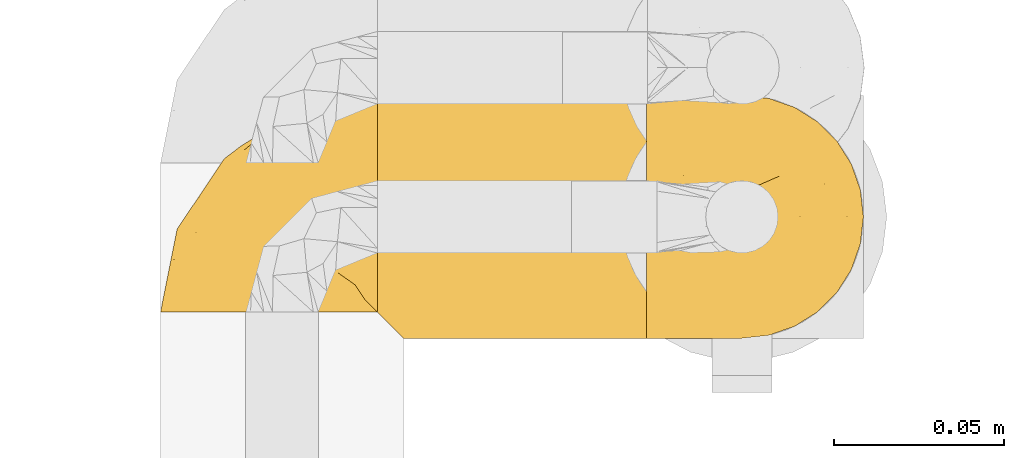
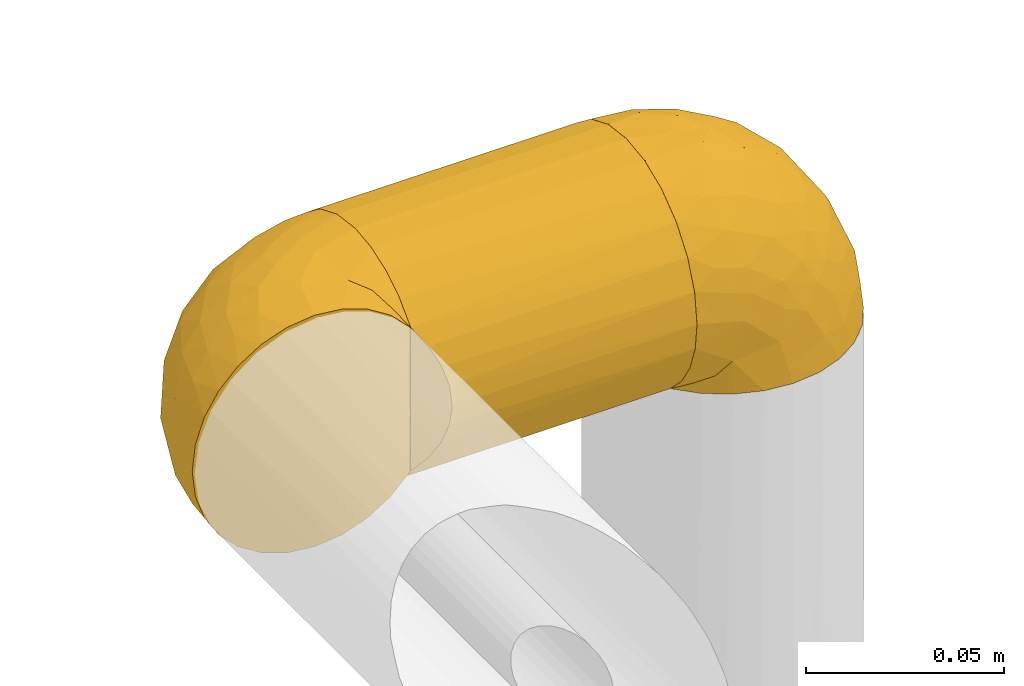
# One storey, part 69 of 827: 3 coverings.
"""IFC2X3 building model written with IfcOpenShell, lengths in millimetres."""

from ifc_helpers import new_model, entity, si_unit, converted_unit, derived_unit, direction, frame, origin, place, context, subcontext, project, spatial, faceted_brep, element, save


model = new_model("IFC2X3")

# Units and contexts
model_context = context("Model", 3, precision=0.01, world=origin(), true_north=direction((6.12303176911189e-17, 1.0)))
body_context = subcontext(model_context, "Body", "Model", "MODEL_VIEW")
ifc_project = project(units=[si_unit("LENGTHUNIT", "METRE", prefix="MILLI"), si_unit("AREAUNIT", "SQUARE_METRE"), si_unit("VOLUMEUNIT", "CUBIC_METRE"), converted_unit("PLANEANGLEUNIT", "DEGREE", entity("IfcRatioMeasure", 0.0174532925199433), si_unit("PLANEANGLEUNIT", "RADIAN"), dimensions=[0, 0, 0, 0, 0, 0, 0]), si_unit("MASSUNIT", "GRAM", prefix="KILO"), derived_unit("MASSDENSITYUNIT", [(si_unit("MASSUNIT", "GRAM", prefix="KILO"), 1), (si_unit("LENGTHUNIT", "METRE"), -3)]), derived_unit("MOMENTOFINERTIAUNIT", [(si_unit("LENGTHUNIT", "METRE"), 4)]), si_unit("TIMEUNIT", "SECOND"), si_unit("FREQUENCYUNIT", "HERTZ"), si_unit("THERMODYNAMICTEMPERATUREUNIT", "DEGREE_CELSIUS"), derived_unit("THERMALTRANSMITTANCEUNIT", [(si_unit("MASSUNIT", "GRAM", prefix="KILO"), 1), (si_unit("THERMODYNAMICTEMPERATUREUNIT", "KELVIN"), -1), (si_unit("TIMEUNIT", "SECOND"), -3)]), derived_unit("VOLUMETRICFLOWRATEUNIT", [(si_unit("LENGTHUNIT", "METRE"), 3), (si_unit("TIMEUNIT", "SECOND"), -1)]), derived_unit("MASSFLOWRATEUNIT", [(si_unit("MASSUNIT", "GRAM", prefix="KILO"), 1), (si_unit("TIMEUNIT", "SECOND"), -1)]), derived_unit("ROTATIONALFREQUENCYUNIT", [(si_unit("TIMEUNIT", "SECOND"), -1)]), si_unit("ELECTRICCURRENTUNIT", "AMPERE"), si_unit("ELECTRICVOLTAGEUNIT", "VOLT"), si_unit("POWERUNIT", "WATT"), si_unit("FORCEUNIT", "NEWTON", prefix="KILO"), si_unit("ILLUMINANCEUNIT", "LUX"), si_unit("LUMINOUSFLUXUNIT", "LUMEN"), si_unit("LUMINOUSINTENSITYUNIT", "CANDELA"), derived_unit("USERDEFINED", [(si_unit("MASSUNIT", "GRAM", prefix="KILO"), -1), (si_unit("LENGTHUNIT", "METRE"), -2), (si_unit("TIMEUNIT", "SECOND"), 3), (si_unit("LUMINOUSFLUXUNIT", "LUMEN"), 1)]), derived_unit("LINEARVELOCITYUNIT", [(si_unit("LENGTHUNIT", "METRE"), 1), (si_unit("TIMEUNIT", "SECOND"), -1)]), si_unit("PRESSUREUNIT", "PASCAL"), derived_unit("USERDEFINED", [(si_unit("LENGTHUNIT", "METRE"), -2), (si_unit("MASSUNIT", "GRAM", prefix="KILO"), 1), (si_unit("TIMEUNIT", "SECOND"), -2)]), derived_unit("LINEARFORCEUNIT", [(si_unit("MASSUNIT", "GRAM", prefix="KILO"), 1), (si_unit("LENGTHUNIT", "METRE"), 1), (si_unit("TIMEUNIT", "SECOND"), -2), (si_unit("LENGTHUNIT", "METRE"), -1)]), derived_unit("PLANARFORCEUNIT", [(si_unit("MASSUNIT", "GRAM", prefix="KILO"), 1), (si_unit("LENGTHUNIT", "METRE"), 1), (si_unit("TIMEUNIT", "SECOND"), -2), (si_unit("LENGTHUNIT", "METRE"), -2)])], contexts=[model_context])

# Site, building, storey
site_placement = place(None, origin())
site = spatial("IfcSite", under=ifc_project, at=site_placement, CompositionType="ELEMENT")
building_placement = place(site_placement, origin())
building = spatial("IfcBuilding", under=site, at=building_placement, CompositionType="ELEMENT")
storey_placement = place(building_placement, frame((0.0, 0.0, 28200.0)))
storey = spatial("IfcBuildingStorey", under=building, at=storey_placement, Name="08", CompositionType="ELEMENT", Elevation=28200.0)

# Coverings
covering_1_placement = place(storey_placement, frame((13301.52, 12341.57, 1262.75)))
element("IfcCovering", 1, at=covering_1_placement, inside=storey, Name=":ADSK_", ObjectType=":ADSK_", PredefinedType="INSULATION", context=body_context, shape_type="Brep", body=[
    faceted_brep([(80.6, 71.99, 29.25), (80.6, 72.9, 37.25), (80.6, 71.68, 46.47), (80.6, 68.12, 55.07), (80.6, 62.45, 62.45), (80.6, 55.07, 68.12), (80.6, 46.47, 71.68), (80.6, 37.25, 72.9), (80.6, 28.02, 71.68), (80.6, 19.42, 68.12), (80.6, 12.04, 62.45), (80.6, 6.37, 55.07), (80.6, 2.81, 46.47), (80.6, 1.6, 37.25), (80.6, 2.5, 29.26), (80.6, 5.17, 21.68), (80.6, 9.47, 14.9), (80.6, 15.18, 9.25), (80.6, 59.31, 9.25), (80.6, 65.02, 14.89), (80.6, 69.32, 21.68), (1.6, 71.68, 28.02), (1.6, 68.12, 19.42), (1.6, 62.45, 12.04), (1.6, 55.07, 6.37), (1.6, 46.47, 2.81), (1.6, 37.25, 1.6), (1.6, 29.26, 2.5), (1.6, 21.68, 5.17), (1.6, 14.89, 9.47), (1.6, 9.25, 15.18), (1.6, 9.25, 59.31), (1.6, 14.89, 65.02), (1.6, 21.68, 69.32), (1.6, 29.26, 71.99), (1.6, 37.25, 72.9), (1.6, 46.47, 71.68), (1.6, 55.07, 68.12), (1.6, 62.45, 62.45), (1.6, 68.12, 55.07), (1.6, 71.68, 46.47), (1.6, 72.9, 37.25), (8.75, 2.09, 31.32), (7.28, 3.56, 25.57), (4.87, 5.97, 20.14), (9.25, 1.6, 37.25), (77.32, 20.14, 5.97), (74.91, 25.57, 3.56), (73.44, 31.32, 2.09), (72.95, 37.25, 1.6), (73.44, 43.17, 2.09), (74.91, 48.92, 3.56), (77.32, 54.35, 5.97), (4.87, 5.97, 54.35), (7.28, 3.56, 48.92), (8.75, 2.09, 43.17)], [[[0, 1, 2, 3, 4, 5, 6, 7, 8, 9, 10, 11, 12, 13, 14, 15, 16, 17, 18, 19, 20]], [[21, 22, 23, 24, 25, 26, 27, 28, 29, 30, 31, 32, 33, 34, 35, 36, 37, 38, 39, 40, 41]], [[42, 43, 14]], [[44, 30, 16]], [[43, 44, 15]], [[45, 42, 13]], [[13, 42, 14]], [[14, 43, 15]], [[44, 16, 15]], [[30, 29, 16]], [[46, 29, 28]], [[47, 28, 27]], [[48, 27, 26]], [[46, 17, 29]], [[48, 47, 27]], [[49, 48, 26]], [[46, 28, 47]], [[29, 17, 16]], [[50, 49, 26]], [[50, 26, 25]], [[51, 25, 24]], [[51, 50, 25]], [[18, 52, 24]], [[51, 24, 52]], [[24, 23, 18]], [[19, 23, 22]], [[20, 22, 21]], [[0, 21, 41]], [[19, 22, 20]], [[20, 21, 0]], [[41, 1, 0]], [[23, 19, 18]], [[2, 1, 41, 40]], [[3, 2, 40, 39]], [[39, 38, 4, 3]], [[6, 5, 37, 36]], [[7, 6, 36, 35]], [[38, 37, 5, 4]], [[7, 35, 34]], [[8, 34, 33]], [[9, 33, 32]], [[7, 34, 8]], [[8, 33, 9]], [[32, 10, 9]], [[32, 31, 10]], [[31, 53, 11]], [[54, 55, 12]], [[53, 54, 11]], [[11, 54, 12]], [[13, 12, 55]], [[45, 13, 55]], [[31, 11, 10]], [[49, 50, 51, 52, 18, 17, 46, 47, 48]], [[30, 44, 43, 42, 45, 55, 54, 53, 31]]]),
])
covering_2_placement = place(storey_placement, frame((13237.87, 12349.22, 1262.75)))
element("IfcCovering", 2, at=covering_2_placement, inside=storey, Name=":ADSK_", ObjectType=":ADSK_", PredefinedType="INSULATION", context=body_context, shape_type="Brep", body=[
    faceted_brep([(21.77, 1.6, 69.36), (15.01, 1.6, 65.11), (9.37, 1.6, 59.47), (5.12, 1.6, 52.71), (2.49, 1.6, 45.17), (1.6, 1.6, 37.25), (2.49, 1.6, 29.31), (5.13, 1.6, 21.77), (9.38, 1.6, 15.01), (15.02, 1.6, 9.37), (21.78, 1.6, 5.12), (29.32, 1.6, 2.49), (37.25, 1.6, 1.6), (45.15, 1.6, 2.48), (52.65, 1.6, 5.1), (59.39, 1.6, 9.31), (65.02, 1.6, 14.9), (65.02, 1.6, 16.96), (65.02, 1.6, 18.43), (65.02, 1.6, 20.19), (65.02, 1.6, 21.96), (65.02, 1.6, 23.72), (65.02, 1.6, 25.49), (65.02, 1.6, 27.25), (65.02, 1.6, 29.02), (65.02, 1.6, 30.78), (65.02, 1.6, 32.55), (65.02, 1.6, 34.31), (65.02, 1.6, 36.08), (65.02, 1.6, 37.84), (65.02, 1.6, 39.61), (65.02, 1.6, 41.37), (65.02, 1.6, 43.14), (65.02, 1.6, 45.19), (65.02, 1.6, 47.25), (65.02, 1.6, 49.31), (65.02, 1.6, 51.36), (65.02, 1.6, 53.42), (65.02, 1.6, 55.48), (65.02, 1.6, 57.53), (65.02, 1.6, 59.59), (59.38, 1.6, 65.19), (52.64, 1.6, 69.4), (45.13, 1.6, 72.01), (37.25, 1.6, 72.9), (29.31, 1.6, 72.0), (65.25, 1.82, 14.9), (65.25, 7.46, 9.3), (65.25, 14.2, 5.09), (65.25, 21.7, 2.48), (65.25, 29.6, 1.6), (65.25, 38.82, 2.81), (65.25, 47.42, 6.37), (65.25, 54.8, 12.04), (65.25, 60.47, 19.42), (65.25, 64.03, 28.02), (65.25, 65.25, 37.25), (65.25, 64.03, 46.47), (65.25, 60.47, 55.07), (65.25, 54.8, 62.45), (65.25, 47.42, 68.12), (65.25, 38.82, 71.68), (65.25, 29.6, 72.9), (65.25, 21.7, 72.01), (65.25, 14.2, 69.4), (65.25, 7.46, 65.19), (65.25, 1.82, 59.59), (65.25, 1.82, 58.56), (65.25, 1.82, 56.8), (65.25, 1.82, 55.4), (65.25, 1.82, 54.0), (65.25, 1.82, 52.61), (65.25, 1.82, 51.21), (65.25, 1.82, 49.81), (65.25, 1.82, 48.42), (65.25, 1.82, 47.02), (65.25, 1.82, 45.62), (65.25, 1.82, 44.23), (65.25, 1.82, 42.83), (65.25, 1.82, 41.43), (65.25, 1.82, 40.04), (65.25, 1.82, 38.64), (65.25, 1.82, 37.25), (65.25, 1.82, 35.48), (65.25, 1.82, 33.72), (65.25, 1.82, 31.95), (65.25, 1.82, 30.19), (65.25, 1.82, 28.42), (65.25, 1.82, 26.66), (65.25, 1.82, 24.89), (65.25, 1.82, 23.13), (65.25, 1.82, 21.07), (65.25, 1.82, 19.01), (65.25, 1.82, 16.96), (65.08, 1.75, 50.36), (65.09, 1.76, 51.91), (65.09, 1.76, 27.73), (65.1, 1.76, 29.06), (65.08, 1.74, 23.0), (65.09, 1.76, 39.29), (65.09, 1.75, 16.3), (65.09, 1.75, 17.69), (65.09, 1.75, 42.09), (65.1, 1.76, 43.53), (65.08, 1.74, 58.23), (65.09, 1.75, 59.59), (65.08, 1.74, 46.32), (65.09, 1.76, 47.68), (65.08, 1.75, 19.0), (65.09, 1.75, 30.39), (65.07, 1.74, 31.67), (65.1, 1.76, 37.94), (65.09, 1.76, 36.57), (65.1, 1.76, 45.01), (65.07, 1.73, 35.19), (65.07, 1.74, 26.37), (65.09, 1.75, 25.1), (65.08, 1.74, 56.91), (65.09, 1.75, 40.68), (65.13, 1.78, 32.77), (65.1, 1.76, 20.34), (65.09, 1.76, 21.67), (65.09, 1.75, 33.92), (65.1, 1.76, 53.39), (65.09, 1.75, 54.7), (65.09, 1.75, 14.9), (65.09, 1.76, 49.03), (53.74, 13.11, 3.58), (57.19, 8.18, 6.24), (51.25, 25.84, 1.6), (59.77, 28.13, 1.6), (41.0, 15.6, 1.6), (61.64, 5.2, 9.92), (46.12, 20.72, 1.6), (38.71, 7.07, 1.6), (13.0, 35.56, 27.59), (5.55, 16.98, 25.47), (6.44, 25.95, 37.25), (55.39, 35.4, 2.33), (48.48, 32.74, 2.37), (39.63, 43.51, 8.53), (43.5, 53.51, 15.54), (52.38, 49.6, 8.96), (49.31, 40.07, 4.31), (58.01, 42.61, 4.31), (22.23, 20.45, 7.06), (19.14, 10.52, 7.06), (13.73, 14.87, 12.03), (39.1, 24.92, 2.3), (15.38, 34.61, 21.13), (46.7, 61.84, 30.63), (49.4, 60.43, 23.6), (4.12, 14.29, 37.25), (55.35, 57.0, 15.54), (23.83, 42.79, 18.65), (19.0, 33.34, 15.3), (32.44, 21.53, 3.14), (26.73, 11.52, 3.59), (8.12, 12.66, 18.27), (31.34, 34.11, 7.07), (38.81, 32.29, 3.86), (16.11, 24.41, 13.04), (11.96, 24.95, 18.27), (20.31, 44.19, 26.27), (38.81, 56.24, 23.06), (35.48, 56.83, 29.25), (28.94, 50.94, 24.41), (25.21, 50.38, 31.04), (20.24, 46.6, 37.25), (13.34, 36.28, 37.25), (52.55, 62.72, 37.25), (33.16, 47.39, 15.08), (27.33, 38.92, 12.03), (22.86, 29.55, 9.82), (27.48, 26.82, 6.14), (40.89, 60.4, 37.25), (30.56, 53.5, 37.25), (54.41, 41.8, 70.18), (46.71, 61.8, 44.04), (26.31, 49.33, 49.17), (12.98, 35.54, 46.9), (13.72, 14.87, 62.45), (8.12, 12.65, 56.21), (46.04, 47.44, 65.53), (51.06, 56.06, 58.95), (35.69, 50.17, 58.17), (22.22, 20.44, 67.43), (19.13, 10.52, 67.43), (26.72, 11.52, 70.89), (19.65, 38.79, 55.13), (51.87, 33.87, 72.21), (51.25, 25.84, 72.9), (58.25, 27.72, 72.9), (38.71, 7.07, 72.9), (54.36, 62.13, 49.42), (56.5, 50.52, 65.53), (34.9, 56.47, 45.41), (43.16, 58.39, 50.89), (5.54, 16.98, 49.01), (35.66, 39.3, 66.8), (47.21, 38.56, 70.39), (11.95, 24.94, 56.21), (46.27, 30.34, 72.31), (39.95, 26.49, 72.1), (41.0, 15.6, 72.9), (46.12, 20.72, 72.9), (18.27, 26.6, 62.45), (32.43, 21.54, 71.35), (58.69, 35.7, 72.26), (27.31, 38.91, 62.45), (29.52, 30.65, 67.99), (35.02, 44.9, 62.85), (40.81, 34.09, 70.57), (53.74, 13.11, 70.91), (58.66, 9.65, 68.25), (61.64, 5.2, 64.57)], [[[0, 1, 2, 3, 4, 5, 6, 7, 8, 9, 10, 11, 12, 13, 14, 15, 16, 17, 18, 19, 20, 21, 22, 23, 24, 25, 26, 27, 28, 29, 30, 31, 32, 33, 34, 35, 36, 37, 38, 39, 40, 41, 42, 43, 44, 45]], [[46, 47, 48, 49, 50, 51, 52, 53, 54, 55, 56, 57, 58, 59, 60, 61, 62, 63, 64, 65, 66, 67, 68, 69, 70, 71, 72, 73, 74, 75, 76, 77, 78, 79, 80, 81, 82, 83, 84, 85, 86, 87, 88, 89, 90, 91, 92, 93]], [[94, 72, 95]], [[96, 87, 97]], [[20, 98, 21]], [[99, 81, 80]], [[100, 93, 101]], [[102, 103, 32]], [[104, 105, 40]], [[67, 105, 104]], [[106, 107, 34]], [[18, 101, 108]], [[109, 85, 110]], [[36, 94, 95]], [[81, 111, 82]], [[29, 28, 112]], [[17, 101, 18]], [[103, 113, 33]], [[24, 96, 97]], [[28, 114, 112]], [[115, 22, 116]], [[31, 102, 32]], [[68, 104, 117]], [[31, 118, 102]], [[84, 119, 85]], [[120, 91, 121]], [[23, 22, 115]], [[114, 27, 122]], [[123, 37, 95]], [[117, 124, 69]], [[67, 66, 105]], [[104, 39, 117]], [[123, 124, 37]], [[100, 17, 16]], [[100, 125, 46]], [[17, 100, 101]], [[107, 126, 35]], [[92, 108, 101]], [[115, 88, 96]], [[114, 122, 83]], [[101, 93, 92]], [[93, 100, 46]], [[16, 125, 100]], [[108, 19, 18]], [[120, 121, 19]], [[108, 92, 120]], [[19, 108, 120]], [[67, 104, 68]], [[39, 104, 40]], [[69, 68, 117]], [[117, 39, 38]], [[70, 124, 123]], [[124, 70, 69]], [[38, 124, 117]], [[124, 38, 37]], [[72, 71, 95]], [[71, 123, 95]], [[71, 70, 123]], [[126, 94, 35]], [[37, 36, 95]], [[75, 74, 107]], [[73, 72, 94]], [[94, 36, 35]], [[94, 126, 73]], [[74, 73, 126]], [[106, 76, 75]], [[76, 106, 113]], [[113, 106, 33]], [[107, 35, 34]], [[106, 34, 33]], [[126, 107, 74]], [[107, 106, 75]], [[78, 77, 103]], [[77, 113, 103]], [[77, 76, 113]], [[102, 78, 103]], [[33, 32, 103]], [[80, 79, 118]], [[102, 118, 79]], [[112, 111, 29]], [[118, 31, 30]], [[79, 78, 102]], [[99, 111, 81]], [[112, 82, 111]], [[111, 99, 29]], [[30, 29, 99]], [[112, 83, 82]], [[27, 114, 28]], [[99, 118, 30]], [[118, 99, 80]], [[114, 83, 112]], [[84, 83, 122]], [[109, 110, 25]], [[122, 27, 26]], [[119, 110, 85]], [[20, 19, 121]], [[25, 110, 26]], [[91, 120, 92]], [[90, 98, 121]], [[121, 91, 90]], [[23, 115, 96]], [[88, 115, 116]], [[116, 98, 89]], [[89, 88, 116]], [[23, 96, 24]], [[87, 96, 88]], [[25, 24, 109]], [[97, 87, 86]], [[90, 89, 98]], [[116, 22, 21]], [[122, 26, 119]], [[86, 85, 109]], [[109, 97, 86]], [[97, 109, 24]], [[110, 119, 26]], [[122, 119, 84]], [[121, 98, 20]], [[21, 98, 116]], [[48, 127, 49]], [[48, 47, 128]], [[49, 129, 130, 50]], [[129, 49, 127]], [[131, 127, 13]], [[46, 125, 132]], [[16, 15, 132]], [[127, 128, 14]], [[127, 131, 133, 129]], [[14, 13, 127]], [[13, 12, 134, 131]], [[46, 132, 47]], [[48, 128, 127]], [[47, 132, 128]], [[15, 128, 132]], [[125, 16, 132]], [[15, 14, 128]], [[135, 136, 137]], [[138, 129, 139]], [[140, 141, 142]], [[143, 144, 138]], [[145, 146, 147]], [[133, 148, 139]], [[134, 12, 11]], [[136, 135, 149]], [[150, 55, 151]], [[136, 6, 152]], [[153, 54, 53]], [[52, 144, 142]], [[52, 142, 53]], [[54, 153, 151]], [[144, 52, 51]], [[154, 155, 149]], [[156, 131, 157]], [[134, 11, 157]], [[8, 7, 158]], [[147, 9, 8]], [[157, 131, 134]], [[157, 11, 10]], [[146, 157, 10]], [[159, 140, 160]], [[157, 145, 156]], [[161, 162, 155]], [[161, 147, 162]], [[154, 149, 163]], [[150, 164, 165]], [[136, 7, 6]], [[137, 136, 152]], [[162, 158, 136]], [[54, 151, 55]], [[158, 147, 8]], [[166, 167, 165]], [[9, 146, 10]], [[164, 166, 165]], [[168, 135, 137, 169]], [[55, 150, 170]], [[154, 171, 172]], [[139, 148, 160]], [[140, 142, 143]], [[153, 142, 141]], [[51, 50, 130]], [[145, 173, 174]], [[156, 160, 148]], [[6, 5, 152]], [[136, 158, 7]], [[147, 158, 162]], [[147, 146, 9]], [[157, 146, 145]], [[160, 140, 143]], [[140, 172, 171]], [[139, 143, 138]], [[173, 159, 174]], [[170, 150, 175]], [[170, 56, 55]], [[167, 168, 176]], [[176, 175, 165]], [[150, 165, 175]], [[163, 167, 166]], [[176, 165, 167]], [[164, 150, 151]], [[151, 141, 164]], [[171, 164, 141]], [[154, 163, 166]], [[163, 135, 168]], [[166, 164, 171]], [[155, 154, 172]], [[166, 171, 154]], [[140, 171, 141]], [[173, 155, 172]], [[149, 155, 162]], [[159, 173, 172]], [[161, 145, 147]], [[140, 159, 172]], [[174, 160, 156]], [[136, 149, 162]], [[149, 135, 163]], [[155, 173, 161]], [[145, 161, 173]], [[160, 174, 159]], [[156, 148, 131]], [[156, 145, 174]], [[142, 153, 53]], [[151, 153, 141]], [[138, 51, 130]], [[142, 144, 143]], [[51, 138, 144]], [[129, 138, 130]], [[133, 139, 129]], [[160, 143, 139]], [[168, 167, 163]], [[131, 148, 133]], [[60, 177, 61]], [[175, 178, 170]], [[179, 168, 180]], [[178, 57, 170]], [[181, 182, 2]], [[183, 184, 185]], [[186, 187, 188]], [[189, 185, 179]], [[190, 191, 192]], [[45, 193, 188]], [[194, 184, 58]], [[45, 44, 193]], [[59, 195, 60]], [[60, 195, 177]], [[0, 45, 188]], [[196, 179, 197]], [[180, 137, 198]], [[183, 199, 200]], [[201, 182, 181]], [[1, 181, 2]], [[57, 178, 194]], [[198, 3, 182]], [[198, 152, 4]], [[1, 0, 187]], [[190, 202, 191]], [[203, 204, 205]], [[206, 201, 181]], [[186, 188, 207]], [[188, 204, 207]], [[3, 198, 4]], [[58, 184, 59]], [[187, 181, 1]], [[180, 198, 201]], [[206, 181, 186]], [[180, 189, 179]], [[3, 2, 182]], [[180, 168, 169, 137]], [[204, 188, 193]], [[177, 190, 208]], [[209, 210, 199]], [[210, 186, 207]], [[185, 184, 197]], [[195, 184, 183]], [[205, 202, 203]], [[210, 209, 206]], [[179, 185, 197]], [[211, 209, 199]], [[196, 197, 178]], [[180, 201, 189]], [[152, 198, 137]], [[152, 5, 4]], [[61, 208, 62]], [[198, 182, 201]], [[188, 187, 0]], [[181, 187, 186]], [[203, 210, 207]], [[202, 205, 191]], [[199, 210, 212]], [[57, 56, 170]], [[176, 196, 175]], [[178, 197, 194]], [[179, 176, 168]], [[175, 196, 178]], [[176, 179, 196]], [[184, 194, 197]], [[58, 57, 194]], [[208, 190, 192]], [[200, 190, 177]], [[206, 189, 201]], [[185, 189, 209]], [[62, 208, 192]], [[177, 208, 61]], [[210, 206, 186]], [[189, 206, 209]], [[200, 199, 212]], [[211, 183, 185]], [[184, 195, 59]], [[177, 195, 183]], [[183, 200, 177]], [[202, 200, 212]], [[200, 202, 190]], [[202, 212, 203]], [[210, 203, 212]], [[204, 203, 207]], [[183, 211, 199]], [[185, 209, 211]], [[63, 62, 192, 191]], [[64, 63, 213]], [[64, 213, 214]], [[65, 215, 66]], [[213, 191, 205, 204]], [[43, 204, 193, 44]], [[65, 214, 215]], [[42, 213, 43]], [[215, 105, 66]], [[41, 214, 42]], [[40, 105, 215]], [[65, 64, 214]], [[40, 215, 41]], [[213, 63, 191]], [[42, 214, 213]], [[204, 43, 213]], [[214, 41, 215]]]),
])
covering_3_placement = place(storey_placement, frame((13380.52, 12341.57, 1270.4)))
element("IfcCovering", 3, at=covering_3_placement, inside=storey, Name=":ADSK_", ObjectType=":ADSK_", PredefinedType="INSULATION", context=body_context, shape_type="Brep", body=[
    faceted_brep([(1.82, 14.9, 1.6), (1.82, 16.96, 1.6), (1.82, 18.43, 1.6), (1.82, 20.19, 1.6), (1.82, 21.96, 1.6), (1.82, 23.72, 1.6), (1.82, 25.49, 1.6), (1.82, 27.25, 1.6), (1.82, 29.02, 1.6), (1.82, 30.78, 1.6), (1.82, 32.55, 1.6), (1.82, 34.31, 1.6), (1.82, 36.08, 1.6), (1.82, 37.84, 1.6), (1.82, 39.61, 1.6), (1.82, 41.37, 1.6), (1.82, 43.14, 1.6), (1.82, 45.19, 1.6), (1.82, 47.25, 1.6), (1.82, 49.31, 1.6), (1.82, 51.36, 1.6), (1.82, 53.42, 1.6), (1.82, 55.48, 1.6), (1.82, 57.53, 1.6), (1.82, 59.59, 1.6), (7.46, 65.19, 1.6), (14.2, 69.4, 1.6), (21.71, 72.01, 1.6), (29.6, 72.9, 1.6), (37.53, 72.0, 1.6), (45.07, 69.36, 1.6), (51.83, 65.11, 1.6), (57.47, 59.47, 1.6), (61.72, 52.71, 1.6), (64.35, 45.17, 1.6), (65.25, 37.25, 1.6), (64.35, 29.31, 1.6), (61.71, 21.77, 1.6), (57.46, 15.01, 1.6), (51.82, 9.37, 1.6), (45.06, 5.12, 1.6), (37.52, 2.49, 1.6), (29.6, 1.6, 1.6), (21.69, 2.48, 1.6), (14.19, 5.1, 1.6), (7.45, 9.31, 1.6), (1.6, 14.9, 1.82), (1.6, 9.3, 7.46), (1.6, 5.09, 14.2), (1.6, 2.48, 21.7), (1.6, 1.6, 29.6), (1.6, 2.81, 38.82), (1.6, 6.37, 47.42), (1.6, 12.04, 54.8), (1.6, 19.42, 60.47), (1.6, 28.02, 64.03), (1.6, 37.25, 65.25), (1.6, 46.47, 64.03), (1.6, 55.07, 60.47), (1.6, 62.45, 54.8), (1.6, 68.12, 47.42), (1.6, 71.68, 38.82), (1.6, 72.9, 29.6), (1.6, 72.01, 21.7), (1.6, 69.4, 14.2), (1.6, 65.19, 7.46), (1.6, 59.59, 1.82), (1.6, 58.56, 1.82), (1.6, 56.8, 1.82), (1.6, 55.4, 1.82), (1.6, 54.0, 1.82), (1.6, 52.61, 1.82), (1.6, 51.21, 1.82), (1.6, 49.81, 1.82), (1.6, 48.42, 1.82), (1.6, 47.02, 1.82), (1.6, 45.62, 1.82), (1.6, 44.23, 1.82), (1.6, 42.83, 1.82), (1.6, 41.44, 1.82), (1.6, 40.04, 1.82), (1.6, 38.64, 1.82), (1.6, 37.25, 1.82), (1.6, 35.48, 1.82), (1.6, 33.72, 1.82), (1.6, 31.95, 1.82), (1.6, 30.19, 1.82), (1.6, 28.42, 1.82), (1.6, 26.66, 1.82), (1.6, 24.89, 1.82), (1.6, 23.13, 1.82), (1.6, 21.07, 1.82), (1.6, 19.01, 1.82), (1.6, 16.96, 1.82), (1.76, 50.36, 1.75), (1.75, 51.91, 1.76), (1.75, 27.73, 1.76), (1.74, 29.06, 1.76), (1.76, 23.0, 1.74), (1.75, 39.29, 1.76), (1.75, 16.3, 1.75), (1.75, 17.69, 1.75), (1.75, 42.09, 1.75), (1.75, 43.53, 1.76), (1.76, 58.23, 1.74), (1.75, 59.59, 1.75), (1.76, 46.32, 1.74), (1.75, 47.68, 1.76), (1.76, 19.0, 1.75), (1.75, 30.39, 1.75), (1.77, 31.67, 1.74), (1.74, 37.94, 1.76), (1.75, 36.57, 1.76), (1.75, 45.01, 1.76), (1.77, 35.19, 1.74), (1.77, 26.37, 1.74), (1.75, 25.1, 1.75), (1.76, 56.91, 1.74), (1.75, 40.68, 1.75), (1.71, 32.77, 1.78), (1.74, 20.34, 1.76), (1.75, 21.67, 1.76), (1.75, 33.92, 1.75), (1.74, 53.39, 1.76), (1.75, 54.7, 1.75), (1.75, 14.9, 1.75), (1.75, 49.03, 1.76), (13.1, 3.58, 13.11), (9.65, 6.24, 8.18), (15.6, 1.6, 25.84), (7.07, 1.6, 28.13), (25.84, 1.6, 15.6), (5.2, 9.92, 5.2), (20.72, 1.6, 20.72), (28.13, 1.6, 7.07), (53.84, 27.59, 35.56), (61.29, 25.47, 16.98), (60.4, 37.25, 25.95), (11.45, 2.33, 35.4), (18.37, 2.37, 32.74), (27.21, 8.53, 43.51), (23.34, 15.54, 53.51), (14.46, 8.96, 49.6), (17.53, 4.31, 40.07), (8.83, 4.31, 42.61), (44.61, 7.06, 20.45), (47.7, 7.06, 10.52), (53.12, 12.03, 14.87), (27.74, 2.3, 24.92), (51.46, 21.13, 34.61), (20.14, 30.63, 61.84), (17.44, 23.6, 60.43), (62.72, 37.25, 14.29), (11.49, 15.54, 57.0), (43.01, 18.65, 42.79), (47.84, 15.3, 33.34), (34.4, 3.14, 21.53), (40.11, 3.59, 11.52), (58.72, 18.27, 12.66), (35.5, 7.07, 34.11), (28.03, 3.86, 32.29), (50.73, 13.04, 24.41), (54.88, 18.27, 24.95), (46.53, 26.27, 44.19), (28.03, 23.06, 56.24), (31.36, 29.25, 56.83), (37.9, 24.41, 50.94), (41.63, 31.04, 50.38), (46.6, 37.25, 46.6), (53.5, 37.25, 36.28), (14.29, 37.25, 62.72), (33.68, 15.08, 47.39), (39.51, 12.03, 38.92), (43.98, 9.82, 29.55), (39.36, 6.14, 26.82), (25.95, 37.25, 60.4), (36.28, 37.25, 53.5), (12.43, 70.18, 41.8), (20.13, 44.04, 61.8), (40.53, 49.17, 49.33), (53.86, 46.9, 35.54), (53.13, 62.45, 14.87), (58.72, 56.21, 12.65), (20.81, 65.53, 47.44), (15.78, 58.95, 56.06), (31.15, 58.17, 50.17), (44.62, 67.43, 20.44), (47.71, 67.43, 10.52), (40.12, 70.89, 11.52), (47.19, 55.13, 38.79), (14.97, 72.21, 33.87), (15.6, 72.9, 25.84), (8.6, 72.9, 27.72), (28.13, 72.9, 7.07), (12.48, 49.42, 62.13), (10.34, 65.53, 50.52), (31.94, 45.41, 56.47), (23.68, 50.89, 58.39), (61.3, 49.01, 16.98), (31.18, 66.8, 39.3), (19.63, 70.39, 38.56), (54.89, 56.21, 24.94), (20.57, 72.31, 30.34), (26.89, 72.1, 26.49), (25.84, 72.9, 15.6), (20.72, 72.9, 20.72), (48.57, 62.45, 26.6), (34.41, 71.35, 21.54), (8.15, 72.26, 35.7), (39.53, 62.45, 38.91), (37.32, 67.99, 30.65), (31.82, 62.85, 44.9), (26.03, 70.57, 34.09), (13.1, 70.91, 13.11), (8.18, 68.25, 9.65), (5.2, 64.57, 5.2)], [[[0, 1, 2, 3, 4, 5, 6, 7, 8, 9, 10, 11, 12, 13, 14, 15, 16, 17, 18, 19, 20, 21, 22, 23, 24, 25, 26, 27, 28, 29, 30, 31, 32, 33, 34, 35, 36, 37, 38, 39, 40, 41, 42, 43, 44, 45]], [[46, 47, 48, 49, 50, 51, 52, 53, 54, 55, 56, 57, 58, 59, 60, 61, 62, 63, 64, 65, 66, 67, 68, 69, 70, 71, 72, 73, 74, 75, 76, 77, 78, 79, 80, 81, 82, 83, 84, 85, 86, 87, 88, 89, 90, 91, 92, 93]], [[94, 72, 95]], [[96, 87, 97]], [[4, 98, 5]], [[99, 81, 80]], [[100, 93, 101]], [[102, 103, 16]], [[104, 105, 24]], [[67, 105, 104]], [[106, 107, 18]], [[2, 101, 108]], [[109, 85, 110]], [[20, 94, 95]], [[81, 111, 82]], [[13, 12, 112]], [[1, 101, 2]], [[103, 113, 17]], [[8, 96, 97]], [[12, 114, 112]], [[115, 6, 116]], [[15, 102, 16]], [[68, 104, 117]], [[15, 118, 102]], [[84, 119, 85]], [[120, 91, 121]], [[7, 6, 115]], [[114, 11, 122]], [[123, 21, 95]], [[117, 124, 69]], [[67, 66, 105]], [[104, 23, 117]], [[123, 124, 21]], [[100, 1, 0]], [[100, 125, 46]], [[1, 100, 101]], [[107, 126, 19]], [[92, 108, 101]], [[115, 88, 96]], [[114, 122, 83]], [[101, 93, 92]], [[93, 100, 46]], [[0, 125, 100]], [[108, 3, 2]], [[120, 121, 3]], [[108, 92, 120]], [[3, 108, 120]], [[67, 104, 68]], [[23, 104, 24]], [[69, 68, 117]], [[117, 23, 22]], [[70, 124, 123]], [[124, 70, 69]], [[22, 124, 117]], [[124, 22, 21]], [[72, 71, 95]], [[71, 123, 95]], [[71, 70, 123]], [[126, 94, 19]], [[21, 20, 95]], [[75, 74, 107]], [[73, 72, 94]], [[94, 20, 19]], [[94, 126, 73]], [[74, 73, 126]], [[106, 76, 75]], [[76, 106, 113]], [[113, 106, 17]], [[107, 19, 18]], [[106, 18, 17]], [[126, 107, 74]], [[107, 106, 75]], [[78, 77, 103]], [[77, 113, 103]], [[77, 76, 113]], [[102, 78, 103]], [[17, 16, 103]], [[80, 79, 118]], [[102, 118, 79]], [[112, 111, 13]], [[118, 15, 14]], [[79, 78, 102]], [[99, 111, 81]], [[112, 82, 111]], [[111, 99, 13]], [[14, 13, 99]], [[112, 83, 82]], [[11, 114, 12]], [[99, 118, 14]], [[118, 99, 80]], [[114, 83, 112]], [[84, 83, 122]], [[109, 110, 9]], [[122, 11, 10]], [[119, 110, 85]], [[4, 3, 121]], [[9, 110, 10]], [[91, 120, 92]], [[90, 98, 121]], [[121, 91, 90]], [[7, 115, 96]], [[88, 115, 116]], [[116, 98, 89]], [[89, 88, 116]], [[7, 96, 8]], [[87, 96, 88]], [[9, 8, 109]], [[97, 87, 86]], [[90, 89, 98]], [[116, 6, 5]], [[122, 10, 119]], [[86, 85, 109]], [[109, 97, 86]], [[97, 109, 8]], [[110, 119, 10]], [[122, 119, 84]], [[121, 98, 4]], [[5, 98, 116]], [[48, 127, 49]], [[48, 47, 128]], [[49, 129, 130, 50]], [[129, 49, 127]], [[131, 127, 43]], [[46, 125, 132]], [[0, 45, 132]], [[127, 128, 44]], [[127, 131, 133, 129]], [[44, 43, 127]], [[43, 42, 134, 131]], [[46, 132, 47]], [[48, 128, 127]], [[47, 132, 128]], [[45, 128, 132]], [[125, 0, 132]], [[45, 44, 128]], [[135, 136, 137]], [[138, 129, 139]], [[140, 141, 142]], [[143, 144, 138]], [[145, 146, 147]], [[133, 148, 139]], [[134, 42, 41]], [[136, 135, 149]], [[150, 55, 151]], [[136, 36, 152]], [[153, 54, 53]], [[52, 144, 142]], [[52, 142, 53]], [[54, 153, 151]], [[144, 52, 51]], [[154, 155, 149]], [[156, 131, 157]], [[134, 41, 157]], [[38, 37, 158]], [[147, 39, 38]], [[157, 131, 134]], [[157, 41, 40]], [[146, 157, 40]], [[159, 140, 160]], [[157, 145, 156]], [[161, 162, 155]], [[161, 147, 162]], [[154, 149, 163]], [[150, 164, 165]], [[136, 37, 36]], [[137, 136, 152]], [[162, 158, 136]], [[54, 151, 55]], [[158, 147, 38]], [[166, 167, 165]], [[39, 146, 40]], [[164, 166, 165]], [[168, 135, 137, 169]], [[55, 150, 170]], [[154, 171, 172]], [[139, 148, 160]], [[140, 142, 143]], [[153, 142, 141]], [[51, 50, 130]], [[145, 173, 174]], [[156, 160, 148]], [[36, 35, 152]], [[136, 158, 37]], [[147, 158, 162]], [[147, 146, 39]], [[157, 146, 145]], [[160, 140, 143]], [[140, 172, 171]], [[139, 143, 138]], [[173, 159, 174]], [[170, 150, 175]], [[170, 56, 55]], [[167, 168, 176]], [[176, 175, 165]], [[150, 165, 175]], [[163, 167, 166]], [[176, 165, 167]], [[164, 150, 151]], [[151, 141, 164]], [[171, 164, 141]], [[154, 163, 166]], [[163, 135, 168]], [[166, 164, 171]], [[155, 154, 172]], [[166, 171, 154]], [[140, 171, 141]], [[173, 155, 172]], [[149, 155, 162]], [[159, 173, 172]], [[161, 145, 147]], [[140, 159, 172]], [[174, 160, 156]], [[136, 149, 162]], [[149, 135, 163]], [[155, 173, 161]], [[145, 161, 173]], [[160, 174, 159]], [[156, 148, 131]], [[156, 145, 174]], [[142, 153, 53]], [[151, 153, 141]], [[138, 51, 130]], [[142, 144, 143]], [[51, 138, 144]], [[129, 138, 130]], [[133, 139, 129]], [[160, 143, 139]], [[168, 167, 163]], [[131, 148, 133]], [[60, 177, 61]], [[175, 178, 170]], [[179, 168, 180]], [[178, 57, 170]], [[181, 182, 32]], [[183, 184, 185]], [[186, 187, 188]], [[189, 185, 179]], [[190, 191, 192]], [[29, 193, 188]], [[194, 184, 58]], [[29, 28, 193]], [[59, 195, 60]], [[60, 195, 177]], [[30, 29, 188]], [[196, 179, 197]], [[180, 137, 198]], [[183, 199, 200]], [[201, 182, 181]], [[31, 181, 32]], [[57, 178, 194]], [[198, 33, 182]], [[198, 152, 34]], [[31, 30, 187]], [[190, 202, 191]], [[203, 204, 205]], [[206, 201, 181]], [[186, 188, 207]], [[188, 204, 207]], [[33, 198, 34]], [[58, 184, 59]], [[187, 181, 31]], [[180, 198, 201]], [[206, 181, 186]], [[180, 189, 179]], [[33, 32, 182]], [[180, 168, 169, 137]], [[204, 188, 193]], [[177, 190, 208]], [[209, 210, 199]], [[210, 186, 207]], [[185, 184, 197]], [[195, 184, 183]], [[205, 202, 203]], [[210, 209, 206]], [[179, 185, 197]], [[211, 209, 199]], [[196, 197, 178]], [[180, 201, 189]], [[152, 198, 137]], [[152, 35, 34]], [[61, 208, 62]], [[198, 182, 201]], [[188, 187, 30]], [[181, 187, 186]], [[203, 210, 207]], [[202, 205, 191]], [[199, 210, 212]], [[57, 56, 170]], [[176, 196, 175]], [[178, 197, 194]], [[179, 176, 168]], [[175, 196, 178]], [[176, 179, 196]], [[184, 194, 197]], [[58, 57, 194]], [[208, 190, 192]], [[200, 190, 177]], [[206, 189, 201]], [[185, 189, 209]], [[62, 208, 192]], [[177, 208, 61]], [[210, 206, 186]], [[189, 206, 209]], [[200, 199, 212]], [[211, 183, 185]], [[184, 195, 59]], [[177, 195, 183]], [[183, 200, 177]], [[202, 200, 212]], [[200, 202, 190]], [[202, 212, 203]], [[210, 203, 212]], [[204, 203, 207]], [[183, 211, 199]], [[185, 209, 211]], [[63, 62, 192, 191]], [[64, 63, 213]], [[64, 213, 214]], [[65, 215, 66]], [[213, 191, 205, 204]], [[27, 204, 193, 28]], [[65, 214, 215]], [[26, 213, 27]], [[215, 105, 66]], [[25, 214, 26]], [[24, 105, 215]], [[65, 64, 214]], [[24, 215, 25]], [[213, 63, 191]], [[26, 214, 213]], [[204, 27, 213]], [[214, 25, 215]]]),
])

save(model, "model.ifc")
